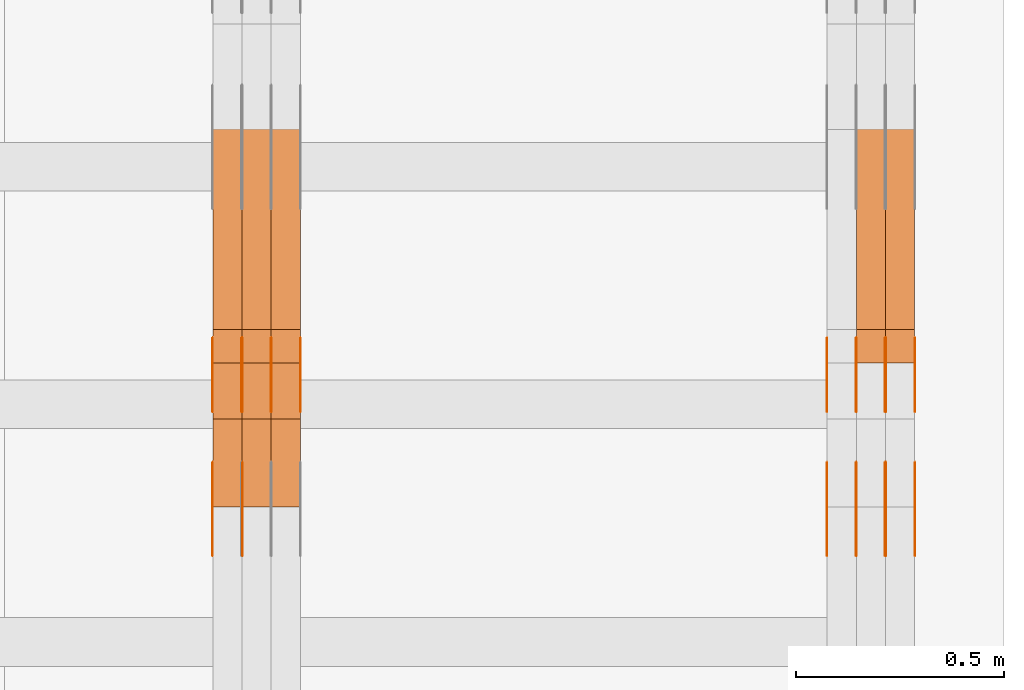
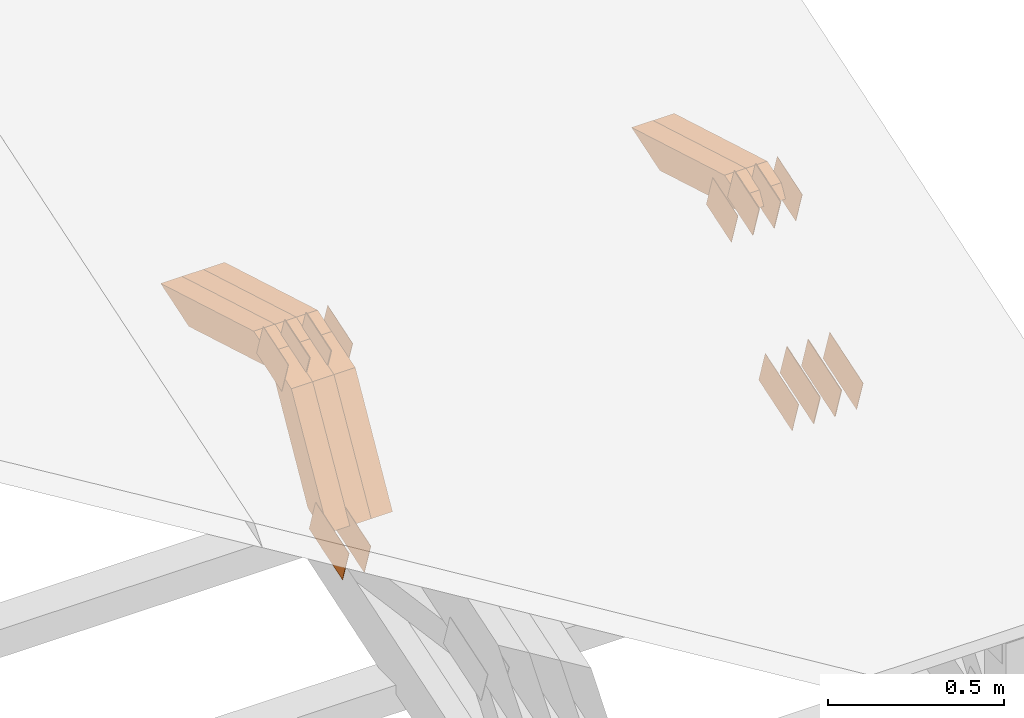
# One storey, part 308 of 385: 28 proxies.
"""IFC2X3 building model written with IfcOpenShell, lengths in millimetres."""

from ifc_helpers import new_model, entity, si_unit, converted_unit, derived_unit, direction, frame, origin, place, context, subcontext, project, spatial, polyline, outline, extrude, source, transform, mapped, material, type_object, type_shapes, element, save


model = new_model("IFC2X3")

# Units and contexts
model_context = context("Model", 3, precision=0.01, world=origin(), true_north=direction((6.12303176911189e-17, 1.0)))
body_context = subcontext(model_context, "Body", "Model", "MODEL_VIEW")
ifc_project = project(units=[si_unit("LENGTHUNIT", "METRE", prefix="MILLI"), si_unit("AREAUNIT", "SQUARE_METRE"), si_unit("VOLUMEUNIT", "CUBIC_METRE"), converted_unit("PLANEANGLEUNIT", "DEGREE", entity("IfcRatioMeasure", 0.0174532925199433), si_unit("PLANEANGLEUNIT", "RADIAN"), dimensions=[0, 0, 0, 0, 0, 0, 0]), si_unit("MASSUNIT", "GRAM", prefix="KILO"), derived_unit("MASSDENSITYUNIT", [(si_unit("MASSUNIT", "GRAM", prefix="KILO"), 1), (si_unit("LENGTHUNIT", "METRE"), -3)]), si_unit("TIMEUNIT", "SECOND"), si_unit("FREQUENCYUNIT", "HERTZ"), si_unit("THERMODYNAMICTEMPERATUREUNIT", "DEGREE_CELSIUS"), derived_unit("THERMALTRANSMITTANCEUNIT", [(si_unit("MASSUNIT", "GRAM", prefix="KILO"), 1), (si_unit("THERMODYNAMICTEMPERATUREUNIT", "KELVIN"), -1), (si_unit("TIMEUNIT", "SECOND"), -3)]), derived_unit("VOLUMETRICFLOWRATEUNIT", [(si_unit("LENGTHUNIT", "METRE"), 3), (si_unit("TIMEUNIT", "SECOND"), -1)]), si_unit("ELECTRICCURRENTUNIT", "AMPERE"), si_unit("ELECTRICVOLTAGEUNIT", "VOLT"), si_unit("POWERUNIT", "WATT"), si_unit("FORCEUNIT", "NEWTON", prefix="KILO"), si_unit("ILLUMINANCEUNIT", "LUX"), si_unit("LUMINOUSFLUXUNIT", "LUMEN"), si_unit("LUMINOUSINTENSITYUNIT", "CANDELA"), derived_unit("USERDEFINED", [(si_unit("MASSUNIT", "GRAM", prefix="KILO"), -1), (si_unit("LENGTHUNIT", "METRE"), -2), (si_unit("TIMEUNIT", "SECOND"), 3), (si_unit("LUMINOUSFLUXUNIT", "LUMEN"), 1)]), derived_unit("LINEARVELOCITYUNIT", [(si_unit("LENGTHUNIT", "METRE"), 1), (si_unit("TIMEUNIT", "SECOND"), -1)]), si_unit("PRESSUREUNIT", "PASCAL"), derived_unit("USERDEFINED", [(si_unit("LENGTHUNIT", "METRE"), -2), (si_unit("MASSUNIT", "GRAM", prefix="KILO"), 1), (si_unit("TIMEUNIT", "SECOND"), -2)])], contexts=[model_context])

# Site, building, storey
site_placement = place(None, origin())
site = spatial("IfcSite", under=ifc_project, at=site_placement, CompositionType="ELEMENT")
building_placement = place(site_placement, origin())
building = spatial("IfcBuilding", under=site, at=building_placement, CompositionType="ELEMENT")
storey_placement = place(building_placement, origin())
storey = spatial("IfcBuildingStorey", under=building, at=storey_placement, Name="Default", CompositionType="ELEMENT", Elevation=0.0)

# Proxies
ifc_material_1 = material(Name="IfcSurfaceStyle #615142")
building_element_proxy_type_1 = type_object("IfcBuildingElementProxyType", PredefinedType="NOTDEFINED", material=ifc_material_1)
shared_shape_1 = source(origin(), body_context, "Body", "SweptSolid", [
    extrude(outline(polyline([(-99.9998204243802, -60.000067376167), (99.9998338462265, -60.000067376167), (99.9998204243802, 60.000067376167), (-99.9998338462265, 60.000067376167), (-99.9998204243802, -60.000067376167)])), frame((100.000602015329, 60.0001864986889, 0.0), z_axis=(0.0, 0.0, 1.0), x_axis=(-1.0, 0.0, 0.0)), (0.0, 0.0, 1.0), 1.3),
])
type_shapes(building_element_proxy_type_1, [shared_shape_1])
proxy_1_placement = place(building_placement, frame((49861.3, 4114.85465165112, 513.097031388771), z_axis=(-1.0, 0.0, 0.0), x_axis=(0.0, 0.951056516295124, 0.309016994375039)))
element("IfcBuildingElementProxy", 1, at=proxy_1_placement, inside=storey, type_object=building_element_proxy_type_1, material=ifc_material_1, context=body_context, shape_type="MappedRepresentation", body=[
    mapped(shared_shape_1, transform((0.0, 0.0, 0.0), scale=1.0)),
])
ifc_material_2 = material(Name="IfcSurfaceStyle #615085")
building_element_proxy_type_2 = type_object("IfcBuildingElementProxyType", PredefinedType="NOTDEFINED", material=ifc_material_2)
shared_shape_2 = source(origin(), body_context, "Body", "SweptSolid", [
    extrude(outline(polyline([(-99.9998204243802, -60.000067376167), (99.9998338462265, -60.000067376167), (99.9998204243802, 60.000067376167), (-99.9998338462265, 60.000067376167), (-99.9998204243802, -60.000067376167)])), frame((100.000602015329, 60.0001864986889, 0.0), z_axis=(0.0, 0.0, 1.0), x_axis=(-1.0, 0.0, 0.0)), (0.0, 0.0, 1.0), 1.3),
])
type_shapes(building_element_proxy_type_2, [shared_shape_2])
proxy_2_placement = place(building_placement, frame((49790.0, 4114.85465165112, 513.097031388771), z_axis=(-1.0, 0.0, 0.0), x_axis=(0.0, 0.951056516295124, 0.309016994375039)))
element("IfcBuildingElementProxy", 2, at=proxy_2_placement, inside=storey, type_object=building_element_proxy_type_2, material=ifc_material_2, context=body_context, shape_type="MappedRepresentation", body=[
    mapped(shared_shape_2, transform((0.0, 0.0, 0.0), scale=1.0)),
])
ifc_material_3 = material(Name="IfcSurfaceStyle #615028")
building_element_proxy_type_3 = type_object("IfcBuildingElementProxyType", PredefinedType="NOTDEFINED", material=ifc_material_3)
shared_shape_3 = source(origin(), body_context, "Body", "SweptSolid", [
    extrude(outline(polyline([(-99.9998204243802, -60.000067376167), (99.9998338462265, -60.000067376167), (99.9998204243802, 60.000067376167), (-99.9998338462265, 60.000067376167), (-99.9998204243802, -60.000067376167)])), frame((100.000602015329, 60.0001864986889, 0.0), z_axis=(0.0, 0.0, 1.0), x_axis=(-1.0, 0.0, 0.0)), (0.0, 0.0, 1.0), 1.3),
])
type_shapes(building_element_proxy_type_3, [shared_shape_3])
proxy_3_placement = place(building_placement, frame((49791.3, 4114.85465165112, 513.097031388771), z_axis=(-1.0, 0.0, 0.0), x_axis=(0.0, 0.951056516295124, 0.309016994375039)))
element("IfcBuildingElementProxy", 3, at=proxy_3_placement, inside=storey, type_object=building_element_proxy_type_3, material=ifc_material_3, context=body_context, shape_type="MappedRepresentation", body=[
    mapped(shared_shape_3, transform((0.0, 0.0, 0.0), scale=1.0)),
])
ifc_material_4 = material(Name="IfcSurfaceStyle #614971")
building_element_proxy_type_4 = type_object("IfcBuildingElementProxyType", PredefinedType="NOTDEFINED", material=ifc_material_4)
shared_shape_4 = source(origin(), body_context, "Body", "SweptSolid", [
    extrude(outline(polyline([(-99.9998204243802, -60.000067376167), (99.9998338462265, -60.000067376167), (99.9998204243802, 60.000067376167), (-99.9998338462265, 60.000067376167), (-99.9998204243802, -60.000067376167)])), frame((100.000602015329, 60.0001864986889, 0.0), z_axis=(0.0, 0.0, 1.0), x_axis=(-1.0, 0.0, 0.0)), (0.0, 0.0, 1.0), 1.29999999999998),
])
type_shapes(building_element_proxy_type_4, [shared_shape_4])
proxy_4_placement = place(building_placement, frame((49720.0, 4114.85465165112, 513.097031388771), z_axis=(-1.0, 0.0, 0.0), x_axis=(0.0, 0.951056516295124, 0.309016994375039)))
element("IfcBuildingElementProxy", 4, at=proxy_4_placement, inside=storey, type_object=building_element_proxy_type_4, material=ifc_material_4, context=body_context, shape_type="MappedRepresentation", body=[
    mapped(shared_shape_4, transform((0.0, 0.0, 0.0), scale=1.0)),
])
ifc_material_5 = material(Name="IfcSurfaceStyle #614914")
building_element_proxy_type_5 = type_object("IfcBuildingElementProxyType", PredefinedType="NOTDEFINED", material=ifc_material_5)
shared_shape_5 = source(origin(), body_context, "Body", "SweptSolid", [
    extrude(outline(polyline([(-99.9998204243802, -60.000067376167), (99.9998338462265, -60.000067376167), (99.9998204243802, 60.000067376167), (-99.9998338462265, 60.000067376167), (-99.9998204243802, -60.000067376167)])), frame((100.000602015329, 60.0001864986889, 0.0), z_axis=(0.0, 0.0, 1.0), x_axis=(-1.0, 0.0, 0.0)), (0.0, 0.0, 1.0), 1.29999999999998),
])
type_shapes(building_element_proxy_type_5, [shared_shape_5])
proxy_5_placement = place(building_placement, frame((49721.3, 4114.85465165112, 513.097031388771), z_axis=(-1.0, 0.0, 0.0), x_axis=(0.0, 0.951056516295124, 0.309016994375039)))
element("IfcBuildingElementProxy", 5, at=proxy_5_placement, inside=storey, type_object=building_element_proxy_type_5, material=ifc_material_5, context=body_context, shape_type="MappedRepresentation", body=[
    mapped(shared_shape_5, transform((0.0, 0.0, 0.0), scale=1.0)),
])
ifc_material_6 = material(Name="IfcSurfaceStyle #614857")
building_element_proxy_type_6 = type_object("IfcBuildingElementProxyType", PredefinedType="NOTDEFINED", material=ifc_material_6)
shared_shape_6 = source(origin(), body_context, "Body", "SweptSolid", [
    extrude(outline(polyline([(-99.9998204243802, -60.000067376167), (99.9998338462265, -60.000067376167), (99.9998204243802, 60.000067376167), (-99.9998338462265, 60.000067376167), (-99.9998204243802, -60.000067376167)])), frame((100.000602015329, 60.0001864986889, 0.0), z_axis=(0.0, 0.0, 1.0), x_axis=(-1.0, 0.0, 0.0)), (0.0, 0.0, 1.0), 1.29999999999999),
])
type_shapes(building_element_proxy_type_6, [shared_shape_6])
proxy_6_placement = place(building_placement, frame((49650.0, 4114.85465165112, 513.097031388771), z_axis=(-1.0, 0.0, 0.0), x_axis=(0.0, 0.951056516295124, 0.309016994375039)))
element("IfcBuildingElementProxy", 6, at=proxy_6_placement, inside=storey, type_object=building_element_proxy_type_6, material=ifc_material_6, context=body_context, shape_type="MappedRepresentation", body=[
    mapped(shared_shape_6, transform((0.0, 0.0, 0.0), scale=1.0)),
])
ifc_material_7 = material(Name="IfcSurfaceStyle #607960")
building_element_proxy_type_7 = type_object("IfcBuildingElementProxyType", PredefinedType="NOTDEFINED", material=ifc_material_7)
shared_shape_7 = source(origin(), body_context, "Body", "SweptSolid", [
    extrude(outline(polyline([(-74.999865998172, -60.0000306612919), (74.999869989555, -60.0000306612919), (74.999865998172, 60.0000306612919), (-74.999869989555, 60.0000306612919), (-74.999865998172, -60.0000306612919)])), frame((75.0006726017528, 60.0001996460842, 0.0), z_axis=(0.0, 0.0, 1.0), x_axis=(-1.0, 0.0, 0.0)), (0.0, 0.0, 1.0), 1.3),
])
type_shapes(building_element_proxy_type_7, [shared_shape_7])
proxy_7_placement = place(building_placement, frame((49861.3, 4460.38978242656, 957.314497110567), z_axis=(-1.0, 0.0, 0.0), x_axis=(0.0, 0.951056516295154, 0.309016994374948)))
element("IfcBuildingElementProxy", 7, at=proxy_7_placement, inside=storey, type_object=building_element_proxy_type_7, material=ifc_material_7, context=body_context, shape_type="MappedRepresentation", body=[
    mapped(shared_shape_7, transform((0.0, 0.0, 0.0), scale=1.0)),
])
ifc_material_8 = material(Name="IfcSurfaceStyle #607903")
building_element_proxy_type_8 = type_object("IfcBuildingElementProxyType", PredefinedType="NOTDEFINED", material=ifc_material_8)
shared_shape_8 = source(origin(), body_context, "Body", "SweptSolid", [
    extrude(outline(polyline([(-74.999865998172, -60.0000306612919), (74.999869989555, -60.0000306612919), (74.999865998172, 60.0000306612919), (-74.999869989555, 60.0000306612919), (-74.999865998172, -60.0000306612919)])), frame((75.0006726017528, 60.0001996460842, 0.0), z_axis=(0.0, 0.0, 1.0), x_axis=(-1.0, 0.0, 0.0)), (0.0, 0.0, 1.0), 1.3),
])
type_shapes(building_element_proxy_type_8, [shared_shape_8])
proxy_8_placement = place(building_placement, frame((49790.0, 4460.38978242656, 957.314497110567), z_axis=(-1.0, 0.0, 0.0), x_axis=(0.0, 0.951056516295154, 0.309016994374948)))
element("IfcBuildingElementProxy", 8, at=proxy_8_placement, inside=storey, type_object=building_element_proxy_type_8, material=ifc_material_8, context=body_context, shape_type="MappedRepresentation", body=[
    mapped(shared_shape_8, transform((0.0, 0.0, 0.0), scale=1.0)),
])
ifc_material_9 = material(Name="IfcSurfaceStyle #607846")
building_element_proxy_type_9 = type_object("IfcBuildingElementProxyType", PredefinedType="NOTDEFINED", material=ifc_material_9)
shared_shape_9 = source(origin(), body_context, "Body", "SweptSolid", [
    extrude(outline(polyline([(-74.999865998172, -60.0000306612919), (74.999869989555, -60.0000306612919), (74.999865998172, 60.0000306612919), (-74.999869989555, 60.0000306612919), (-74.999865998172, -60.0000306612919)])), frame((75.0006726017528, 60.0001996460842, 0.0), z_axis=(0.0, 0.0, 1.0), x_axis=(-1.0, 0.0, 0.0)), (0.0, 0.0, 1.0), 1.3),
])
type_shapes(building_element_proxy_type_9, [shared_shape_9])
proxy_9_placement = place(building_placement, frame((49791.3, 4460.38978242656, 957.314497110567), z_axis=(-1.0, 0.0, 0.0), x_axis=(0.0, 0.951056516295154, 0.309016994374948)))
element("IfcBuildingElementProxy", 9, at=proxy_9_placement, inside=storey, type_object=building_element_proxy_type_9, material=ifc_material_9, context=body_context, shape_type="MappedRepresentation", body=[
    mapped(shared_shape_9, transform((0.0, 0.0, 0.0), scale=1.0)),
])
ifc_material_10 = material(Name="IfcSurfaceStyle #607789")
building_element_proxy_type_10 = type_object("IfcBuildingElementProxyType", PredefinedType="NOTDEFINED", material=ifc_material_10)
shared_shape_10 = source(origin(), body_context, "Body", "SweptSolid", [
    extrude(outline(polyline([(-74.999865998172, -60.0000306612919), (74.999869989555, -60.0000306612919), (74.999865998172, 60.0000306612919), (-74.999869989555, 60.0000306612919), (-74.999865998172, -60.0000306612919)])), frame((75.0006726017528, 60.0001996460842, 0.0), z_axis=(0.0, 0.0, 1.0), x_axis=(-1.0, 0.0, 0.0)), (0.0, 0.0, 1.0), 1.29999999999999),
])
type_shapes(building_element_proxy_type_10, [shared_shape_10])
proxy_10_placement = place(building_placement, frame((49720.0, 4460.38978242656, 957.314497110567), z_axis=(-1.0, 0.0, 0.0), x_axis=(0.0, 0.951056516295154, 0.309016994374948)))
element("IfcBuildingElementProxy", 10, at=proxy_10_placement, inside=storey, type_object=building_element_proxy_type_10, material=ifc_material_10, context=body_context, shape_type="MappedRepresentation", body=[
    mapped(shared_shape_10, transform((0.0, 0.0, 0.0), scale=1.0)),
])
ifc_material_11 = material(Name="IfcSurfaceStyle #607732")
building_element_proxy_type_11 = type_object("IfcBuildingElementProxyType", PredefinedType="NOTDEFINED", material=ifc_material_11)
shared_shape_11 = source(origin(), body_context, "Body", "SweptSolid", [
    extrude(outline(polyline([(-74.999865998172, -60.0000306612919), (74.999869989555, -60.0000306612919), (74.999865998172, 60.0000306612919), (-74.999869989555, 60.0000306612919), (-74.999865998172, -60.0000306612919)])), frame((75.0006726017528, 60.0001996460842, 0.0), z_axis=(0.0, 0.0, 1.0), x_axis=(-1.0, 0.0, 0.0)), (0.0, 0.0, 1.0), 1.29999999999999),
])
type_shapes(building_element_proxy_type_11, [shared_shape_11])
proxy_11_placement = place(building_placement, frame((49721.3, 4460.38978242656, 957.314497110567), z_axis=(-1.0, 0.0, 0.0), x_axis=(0.0, 0.951056516295154, 0.309016994374948)))
element("IfcBuildingElementProxy", 11, at=proxy_11_placement, inside=storey, type_object=building_element_proxy_type_11, material=ifc_material_11, context=body_context, shape_type="MappedRepresentation", body=[
    mapped(shared_shape_11, transform((0.0, 0.0, 0.0), scale=1.0)),
])
ifc_material_12 = material(Name="IfcSurfaceStyle #607675")
building_element_proxy_type_12 = type_object("IfcBuildingElementProxyType", PredefinedType="NOTDEFINED", material=ifc_material_12)
shared_shape_12 = source(origin(), body_context, "Body", "SweptSolid", [
    extrude(outline(polyline([(-74.999865998172, -60.0000306612919), (74.999869989555, -60.0000306612919), (74.999865998172, 60.0000306612919), (-74.999869989555, 60.0000306612919), (-74.999865998172, -60.0000306612919)])), frame((75.0006726017528, 60.0001996460842, 0.0), z_axis=(0.0, 0.0, 1.0), x_axis=(-1.0, 0.0, 0.0)), (0.0, 0.0, 1.0), 1.29999999999999),
])
type_shapes(building_element_proxy_type_12, [shared_shape_12])
proxy_12_placement = place(building_placement, frame((49650.0, 4460.38978242656, 957.314497110567), z_axis=(-1.0, 0.0, 0.0), x_axis=(0.0, 0.951056516295154, 0.309016994374948)))
element("IfcBuildingElementProxy", 12, at=proxy_12_placement, inside=storey, type_object=building_element_proxy_type_12, material=ifc_material_12, context=body_context, shape_type="MappedRepresentation", body=[
    mapped(shared_shape_12, transform((0.0, 0.0, 0.0), scale=1.0)),
])
ifc_material_13 = material(Name="IfcSurfaceStyle #595432")
building_element_proxy_type_13 = type_object("IfcBuildingElementProxyType", Name="T2-W12 595430", PredefinedType="NOTDEFINED", material=ifc_material_13)
shared_shape_13 = source(origin(), body_context, "Body", "SweptSolid", [
    extrude(outline(polyline([(-249.405625983165, -47.5001691155616), (243.345753908996, -47.5001691155616), (232.115534842595, 2.39993474701938e-05), (162.527010966644, 47.5001571158879), (-388.58267373507, 47.5001571158879), (-249.405625983165, -47.5001691155616)])), frame((243.345867653852, 47.5001571158879, 0.0), z_axis=(0.0, 0.0, 1.0), x_axis=(-1.0, 0.0, 0.0)), (0.0, 0.0, 1.0), 70.0),
])
type_shapes(building_element_proxy_type_13, [shared_shape_13])
proxy_13_placement = place(building_placement, frame((49860.0, 4581.32698473631, 976.172276753357), z_axis=(-1.0, 0.0, 0.0), x_axis=(0.0, 0.959722067881787, -0.280951156645966)))
element("IfcBuildingElementProxy", 13, at=proxy_13_placement, inside=storey, type_object=building_element_proxy_type_13, material=ifc_material_13, Name="T2-W12", context=body_context, shape_type="MappedRepresentation", body=[
    mapped(shared_shape_13, transform((0.0, 0.0, 0.0), scale=1.0)),
])
ifc_material_14 = material(Name="IfcSurfaceStyle #595366")
building_element_proxy_type_14 = type_object("IfcBuildingElementProxyType", Name="T2-W12 595364", PredefinedType="NOTDEFINED", material=ifc_material_14)
shared_shape_14 = source(origin(), body_context, "Body", "SweptSolid", [
    extrude(outline(polyline([(-249.405625983165, -47.5001691155616), (243.345753908996, -47.5001691155616), (232.115534842595, 2.39993474701938e-05), (162.527010966644, 47.5001571158879), (-388.58267373507, 47.5001571158879), (-249.405625983165, -47.5001691155616)])), frame((243.345867653852, 47.5001571158879, 0.0), z_axis=(0.0, 0.0, 1.0), x_axis=(-1.0, 0.0, 0.0)), (0.0, 0.0, 1.0), 70.0),
])
type_shapes(building_element_proxy_type_14, [shared_shape_14])
proxy_14_placement = place(building_placement, frame((49790.0, 4581.32698473631, 976.172276753357), z_axis=(-1.0, 0.0, 0.0), x_axis=(0.0, 0.959722067881787, -0.280951156645966)))
element("IfcBuildingElementProxy", 14, at=proxy_14_placement, inside=storey, type_object=building_element_proxy_type_14, material=ifc_material_14, Name="T2-W12", context=body_context, shape_type="MappedRepresentation", body=[
    mapped(shared_shape_14, transform((0.0, 0.0, 0.0), scale=1.0)),
])
ifc_material_15 = material(Name="IfcSurfaceStyle #580482")
building_element_proxy_type_15 = type_object("IfcBuildingElementProxyType", PredefinedType="NOTDEFINED", material=ifc_material_15)
shared_shape_15 = source(origin(), body_context, "Body", "SweptSolid", [
    extrude(outline(polyline([(-99.9998204243802, -60.000067376167), (99.9998338462265, -60.000067376167), (99.9998204243802, 60.000067376167), (-99.9998338462265, 60.000067376167), (-99.9998204243802, -60.000067376167)])), frame((100.000602015329, 60.0001864986889, 0.0), z_axis=(0.0, 0.0, 1.0), x_axis=(-1.0, 0.0, 0.0)), (0.0, 0.0, 1.0), 1.29999999999998),
])
type_shapes(building_element_proxy_type_15, [shared_shape_15])
proxy_15_placement = place(building_placement, frame((48246.3, 4114.85465165113, 513.097031388771), z_axis=(-1.0, 0.0, 0.0), x_axis=(0.0, 0.951056516295124, 0.309016994375039)))
element("IfcBuildingElementProxy", 15, at=proxy_15_placement, inside=storey, type_object=building_element_proxy_type_15, material=ifc_material_15, context=body_context, shape_type="MappedRepresentation", body=[
    mapped(shared_shape_15, transform((0.0, 0.0, 0.0), scale=1.0)),
])
ifc_material_16 = material(Name="IfcSurfaceStyle #580425")
building_element_proxy_type_16 = type_object("IfcBuildingElementProxyType", PredefinedType="NOTDEFINED", material=ifc_material_16)
shared_shape_16 = source(origin(), body_context, "Body", "SweptSolid", [
    extrude(outline(polyline([(-99.9998204243802, -60.000067376167), (99.9998338462265, -60.000067376167), (99.9998204243802, 60.000067376167), (-99.9998338462265, 60.000067376167), (-99.9998204243802, -60.000067376167)])), frame((100.000602015329, 60.0001864986889, 0.0), z_axis=(0.0, 0.0, 1.0), x_axis=(-1.0, 0.0, 0.0)), (0.0, 0.0, 1.0), 1.29999999999999),
])
type_shapes(building_element_proxy_type_16, [shared_shape_16])
proxy_16_placement = place(building_placement, frame((48175.0, 4114.85465165113, 513.097031388771), z_axis=(-1.0, 0.0, 0.0), x_axis=(0.0, 0.951056516295124, 0.309016994375039)))
element("IfcBuildingElementProxy", 16, at=proxy_16_placement, inside=storey, type_object=building_element_proxy_type_16, material=ifc_material_16, context=body_context, shape_type="MappedRepresentation", body=[
    mapped(shared_shape_16, transform((0.0, 0.0, 0.0), scale=1.0)),
])
ifc_material_17 = material(Name="IfcSurfaceStyle #573528")
building_element_proxy_type_17 = type_object("IfcBuildingElementProxyType", PredefinedType="NOTDEFINED", material=ifc_material_17)
shared_shape_17 = source(origin(), body_context, "Body", "SweptSolid", [
    extrude(outline(polyline([(-74.999865998172, -60.0000306612919), (74.999869989555, -60.0000306612919), (74.999865998172, 60.0000306612919), (-74.999869989555, 60.0000306612919), (-74.999865998172, -60.0000306612919)])), frame((75.0006726017528, 60.0001996460842, 0.0), z_axis=(0.0, 0.0, 1.0), x_axis=(-1.0, 0.0, 0.0)), (0.0, 0.0, 1.0), 1.3),
])
type_shapes(building_element_proxy_type_17, [shared_shape_17])
proxy_17_placement = place(building_placement, frame((48386.3, 4460.38978242656, 957.314497110567), z_axis=(-1.0, 0.0, 0.0), x_axis=(0.0, 0.951056516295154, 0.309016994374948)))
element("IfcBuildingElementProxy", 17, at=proxy_17_placement, inside=storey, type_object=building_element_proxy_type_17, material=ifc_material_17, context=body_context, shape_type="MappedRepresentation", body=[
    mapped(shared_shape_17, transform((0.0, 0.0, 0.0), scale=1.0)),
])
ifc_material_18 = material(Name="IfcSurfaceStyle #573471")
building_element_proxy_type_18 = type_object("IfcBuildingElementProxyType", PredefinedType="NOTDEFINED", material=ifc_material_18)
shared_shape_18 = source(origin(), body_context, "Body", "SweptSolid", [
    extrude(outline(polyline([(-74.999865998172, -60.0000306612919), (74.999869989555, -60.0000306612919), (74.999865998172, 60.0000306612919), (-74.999869989555, 60.0000306612919), (-74.999865998172, -60.0000306612919)])), frame((75.0006726017528, 60.0001996460842, 0.0), z_axis=(0.0, 0.0, 1.0), x_axis=(-1.0, 0.0, 0.0)), (0.0, 0.0, 1.0), 1.3),
])
type_shapes(building_element_proxy_type_18, [shared_shape_18])
proxy_18_placement = place(building_placement, frame((48315.0, 4460.38978242656, 957.314497110567), z_axis=(-1.0, 0.0, 0.0), x_axis=(0.0, 0.951056516295154, 0.309016994374948)))
element("IfcBuildingElementProxy", 18, at=proxy_18_placement, inside=storey, type_object=building_element_proxy_type_18, material=ifc_material_18, context=body_context, shape_type="MappedRepresentation", body=[
    mapped(shared_shape_18, transform((0.0, 0.0, 0.0), scale=1.0)),
])
ifc_material_19 = material(Name="IfcSurfaceStyle #573414")
building_element_proxy_type_19 = type_object("IfcBuildingElementProxyType", PredefinedType="NOTDEFINED", material=ifc_material_19)
shared_shape_19 = source(origin(), body_context, "Body", "SweptSolid", [
    extrude(outline(polyline([(-74.999865998172, -60.0000306612919), (74.999869989555, -60.0000306612919), (74.999865998172, 60.0000306612919), (-74.999869989555, 60.0000306612919), (-74.999865998172, -60.0000306612919)])), frame((75.0006726017528, 60.0001996460842, 0.0), z_axis=(0.0, 0.0, 1.0), x_axis=(-1.0, 0.0, 0.0)), (0.0, 0.0, 1.0), 1.3),
])
type_shapes(building_element_proxy_type_19, [shared_shape_19])
proxy_19_placement = place(building_placement, frame((48316.3, 4460.38978242656, 957.314497110567), z_axis=(-1.0, 0.0, 0.0), x_axis=(0.0, 0.951056516295154, 0.309016994374948)))
element("IfcBuildingElementProxy", 19, at=proxy_19_placement, inside=storey, type_object=building_element_proxy_type_19, material=ifc_material_19, context=body_context, shape_type="MappedRepresentation", body=[
    mapped(shared_shape_19, transform((0.0, 0.0, 0.0), scale=1.0)),
])
ifc_material_20 = material(Name="IfcSurfaceStyle #573357")
building_element_proxy_type_20 = type_object("IfcBuildingElementProxyType", PredefinedType="NOTDEFINED", material=ifc_material_20)
shared_shape_20 = source(origin(), body_context, "Body", "SweptSolid", [
    extrude(outline(polyline([(-74.999865998172, -60.0000306612919), (74.999869989555, -60.0000306612919), (74.999865998172, 60.0000306612919), (-74.999869989555, 60.0000306612919), (-74.999865998172, -60.0000306612919)])), frame((75.0006726017528, 60.0001996460842, 0.0), z_axis=(0.0, 0.0, 1.0), x_axis=(-1.0, 0.0, 0.0)), (0.0, 0.0, 1.0), 1.29999999999999),
])
type_shapes(building_element_proxy_type_20, [shared_shape_20])
proxy_20_placement = place(building_placement, frame((48245.0, 4460.38978242656, 957.314497110567), z_axis=(-1.0, 0.0, 0.0), x_axis=(0.0, 0.951056516295154, 0.309016994374948)))
element("IfcBuildingElementProxy", 20, at=proxy_20_placement, inside=storey, type_object=building_element_proxy_type_20, material=ifc_material_20, context=body_context, shape_type="MappedRepresentation", body=[
    mapped(shared_shape_20, transform((0.0, 0.0, 0.0), scale=1.0)),
])
ifc_material_21 = material(Name="IfcSurfaceStyle #573300")
building_element_proxy_type_21 = type_object("IfcBuildingElementProxyType", PredefinedType="NOTDEFINED", material=ifc_material_21)
shared_shape_21 = source(origin(), body_context, "Body", "SweptSolid", [
    extrude(outline(polyline([(-74.999865998172, -60.0000306612919), (74.999869989555, -60.0000306612919), (74.999865998172, 60.0000306612919), (-74.999869989555, 60.0000306612919), (-74.999865998172, -60.0000306612919)])), frame((75.0006726017528, 60.0001996460842, 0.0), z_axis=(0.0, 0.0, 1.0), x_axis=(-1.0, 0.0, 0.0)), (0.0, 0.0, 1.0), 1.29999999999999),
])
type_shapes(building_element_proxy_type_21, [shared_shape_21])
proxy_21_placement = place(building_placement, frame((48246.3, 4460.38978242656, 957.314497110567), z_axis=(-1.0, 0.0, 0.0), x_axis=(0.0, 0.951056516295154, 0.309016994374948)))
element("IfcBuildingElementProxy", 21, at=proxy_21_placement, inside=storey, type_object=building_element_proxy_type_21, material=ifc_material_21, context=body_context, shape_type="MappedRepresentation", body=[
    mapped(shared_shape_21, transform((0.0, 0.0, 0.0), scale=1.0)),
])
ifc_material_22 = material(Name="IfcSurfaceStyle #573243")
building_element_proxy_type_22 = type_object("IfcBuildingElementProxyType", PredefinedType="NOTDEFINED", material=ifc_material_22)
shared_shape_22 = source(origin(), body_context, "Body", "SweptSolid", [
    extrude(outline(polyline([(-74.999865998172, -60.0000306612919), (74.999869989555, -60.0000306612919), (74.999865998172, 60.0000306612919), (-74.999869989555, 60.0000306612919), (-74.999865998172, -60.0000306612919)])), frame((75.0006726017528, 60.0001996460842, 0.0), z_axis=(0.0, 0.0, 1.0), x_axis=(-1.0, 0.0, 0.0)), (0.0, 0.0, 1.0), 1.29999999999999),
])
type_shapes(building_element_proxy_type_22, [shared_shape_22])
proxy_22_placement = place(building_placement, frame((48175.0, 4460.38978242656, 957.314497110567), z_axis=(-1.0, 0.0, 0.0), x_axis=(0.0, 0.951056516295154, 0.309016994374948)))
element("IfcBuildingElementProxy", 22, at=proxy_22_placement, inside=storey, type_object=building_element_proxy_type_22, material=ifc_material_22, context=body_context, shape_type="MappedRepresentation", body=[
    mapped(shared_shape_22, transform((0.0, 0.0, 0.0), scale=1.0)),
])
ifc_material_23 = material(Name="IfcSurfaceStyle #561000")
building_element_proxy_type_23 = type_object("IfcBuildingElementProxyType", Name="T1-W12 560998", PredefinedType="NOTDEFINED", material=ifc_material_23)
shared_shape_23 = source(origin(), body_context, "Body", "SweptSolid", [
    extrude(outline(polyline([(-249.405625983165, -47.5001691155616), (243.345753908996, -47.5001691155616), (232.115534842595, 2.39993474701938e-05), (162.527010966644, 47.5001571158879), (-388.58267373507, 47.5001571158879), (-249.405625983165, -47.5001691155616)])), frame((243.345867653852, 47.5001571158879, 0.0), z_axis=(0.0, 0.0, 1.0), x_axis=(-1.0, 0.0, 0.0)), (0.0, 0.0, 1.0), 70.0),
])
type_shapes(building_element_proxy_type_23, [shared_shape_23])
proxy_23_placement = place(building_placement, frame((48385.0, 4581.32698473632, 976.172276753357), z_axis=(-1.0, 0.0, 0.0), x_axis=(0.0, 0.959722067881787, -0.280951156645966)))
element("IfcBuildingElementProxy", 23, at=proxy_23_placement, inside=storey, type_object=building_element_proxy_type_23, material=ifc_material_23, Name="T1-W12", context=body_context, shape_type="MappedRepresentation", body=[
    mapped(shared_shape_23, transform((0.0, 0.0, 0.0), scale=1.0)),
])
ifc_material_24 = material(Name="IfcSurfaceStyle #560934")
building_element_proxy_type_24 = type_object("IfcBuildingElementProxyType", Name="T1-W12 560932", PredefinedType="NOTDEFINED", material=ifc_material_24)
shared_shape_24 = source(origin(), body_context, "Body", "SweptSolid", [
    extrude(outline(polyline([(-249.405625983165, -47.5001691155616), (243.345753908996, -47.5001691155616), (232.115534842595, 2.39993474701938e-05), (162.527010966644, 47.5001571158879), (-388.58267373507, 47.5001571158879), (-249.405625983165, -47.5001691155616)])), frame((243.345867653852, 47.5001571158879, 0.0), z_axis=(0.0, 0.0, 1.0), x_axis=(-1.0, 0.0, 0.0)), (0.0, 0.0, 1.0), 70.0),
])
type_shapes(building_element_proxy_type_24, [shared_shape_24])
proxy_24_placement = place(building_placement, frame((48315.0, 4581.32698473632, 976.172276753357), z_axis=(-1.0, 0.0, 0.0), x_axis=(0.0, 0.959722067881787, -0.280951156645966)))
element("IfcBuildingElementProxy", 24, at=proxy_24_placement, inside=storey, type_object=building_element_proxy_type_24, material=ifc_material_24, Name="T1-W12", context=body_context, shape_type="MappedRepresentation", body=[
    mapped(shared_shape_24, transform((0.0, 0.0, 0.0), scale=1.0)),
])
ifc_material_25 = material(Name="IfcSurfaceStyle #560868")
building_element_proxy_type_25 = type_object("IfcBuildingElementProxyType", Name="T1-W12 560866", PredefinedType="NOTDEFINED", material=ifc_material_25)
shared_shape_25 = source(origin(), body_context, "Body", "SweptSolid", [
    extrude(outline(polyline([(-249.405625983165, -47.5001691155616), (243.345753908996, -47.5001691155616), (232.115534842595, 2.39993474701938e-05), (162.527010966644, 47.5001571158879), (-388.58267373507, 47.5001571158879), (-249.405625983165, -47.5001691155616)])), frame((243.345867653852, 47.5001571158879, 0.0), z_axis=(0.0, 0.0, 1.0), x_axis=(-1.0, 0.0, 0.0)), (0.0, 0.0, 1.0), 70.0),
])
type_shapes(building_element_proxy_type_25, [shared_shape_25])
proxy_25_placement = place(building_placement, frame((48245.0, 4581.32698473632, 976.172276753357), z_axis=(-1.0, 0.0, 0.0), x_axis=(0.0, 0.959722067881787, -0.280951156645966)))
element("IfcBuildingElementProxy", 25, at=proxy_25_placement, inside=storey, type_object=building_element_proxy_type_25, material=ifc_material_25, Name="T1-W12", context=body_context, shape_type="MappedRepresentation", body=[
    mapped(shared_shape_25, transform((0.0, 0.0, 0.0), scale=1.0)),
])
ifc_material_26 = material(Name="IfcSurfaceStyle #560604")
building_element_proxy_type_26 = type_object("IfcBuildingElementProxyType", Name="T1-W27 560602", PredefinedType="NOTDEFINED", material=ifc_material_26)
shared_shape_26 = source(origin(), body_context, "Body", "SweptSolid", [
    extrude(outline(polyline([(-321.979763159708, -47.49993999164), (138.960018341432, -47.49993999164), (191.013775341887, -0.000473170132329126), (209.87827169492, 47.5001765767061), (-217.872302218531, 47.5001765767062), (-321.979763159708, -47.49993999164)])), frame((209.87827169492, 47.5001765767061, 0.0), z_axis=(0.0, 0.0, 1.0), x_axis=(-1.0, 0.0, 0.0)), (0.0, 0.0, 1.0), 70.0),
])
type_shapes(building_element_proxy_type_26, [shared_shape_26])
proxy_26_placement = place(building_placement, frame((48385.0, 4233.31250000001, 512.021728515625), z_axis=(-1.0, 0.0, 0.0), x_axis=(0.0, 0.494231057369727, 0.869330582650352)))
element("IfcBuildingElementProxy", 26, at=proxy_26_placement, inside=storey, type_object=building_element_proxy_type_26, material=ifc_material_26, Name="T1-W27", context=body_context, shape_type="MappedRepresentation", body=[
    mapped(shared_shape_26, transform((0.0, 0.0, 0.0), scale=1.0)),
])
ifc_material_27 = material(Name="IfcSurfaceStyle #560538")
building_element_proxy_type_27 = type_object("IfcBuildingElementProxyType", Name="T1-W27 560536", PredefinedType="NOTDEFINED", material=ifc_material_27)
shared_shape_27 = source(origin(), body_context, "Body", "SweptSolid", [
    extrude(outline(polyline([(-321.979763159708, -47.49993999164), (138.960018341432, -47.49993999164), (191.013775341887, -0.000473170132329126), (209.87827169492, 47.5001765767061), (-217.872302218531, 47.5001765767062), (-321.979763159708, -47.49993999164)])), frame((209.87827169492, 47.5001765767061, 0.0), z_axis=(0.0, 0.0, 1.0), x_axis=(-1.0, 0.0, 0.0)), (0.0, 0.0, 1.0), 70.0),
])
type_shapes(building_element_proxy_type_27, [shared_shape_27])
proxy_27_placement = place(building_placement, frame((48315.0, 4233.31250000001, 512.021728515625), z_axis=(-1.0, 0.0, 0.0), x_axis=(0.0, 0.494231057369727, 0.869330582650352)))
element("IfcBuildingElementProxy", 27, at=proxy_27_placement, inside=storey, type_object=building_element_proxy_type_27, material=ifc_material_27, Name="T1-W27", context=body_context, shape_type="MappedRepresentation", body=[
    mapped(shared_shape_27, transform((0.0, 0.0, 0.0), scale=1.0)),
])
ifc_material_28 = material(Name="IfcSurfaceStyle #560472")
building_element_proxy_type_28 = type_object("IfcBuildingElementProxyType", Name="T1-W27 560470", PredefinedType="NOTDEFINED", material=ifc_material_28)
shared_shape_28 = source(origin(), body_context, "Body", "SweptSolid", [
    extrude(outline(polyline([(-321.979763159708, -47.49993999164), (138.960018341432, -47.49993999164), (191.013775341887, -0.000473170132329126), (209.87827169492, 47.5001765767061), (-217.872302218531, 47.5001765767062), (-321.979763159708, -47.49993999164)])), frame((209.87827169492, 47.5001765767061, 0.0), z_axis=(0.0, 0.0, 1.0), x_axis=(-1.0, 0.0, 0.0)), (0.0, 0.0, 1.0), 70.0),
])
type_shapes(building_element_proxy_type_28, [shared_shape_28])
proxy_28_placement = place(building_placement, frame((48245.0, 4233.31250000001, 512.021728515625), z_axis=(-1.0, 0.0, 0.0), x_axis=(0.0, 0.494231057369727, 0.869330582650352)))
element("IfcBuildingElementProxy", 28, at=proxy_28_placement, inside=storey, type_object=building_element_proxy_type_28, material=ifc_material_28, Name="T1-W27", context=body_context, shape_type="MappedRepresentation", body=[
    mapped(shared_shape_28, transform((0.0, 0.0, 0.0), scale=1.0)),
])

save(model, "model.ifc")
